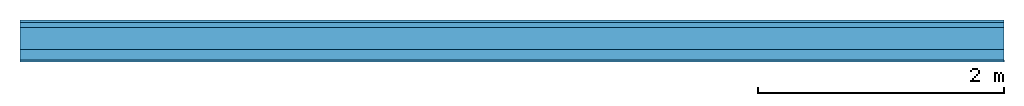
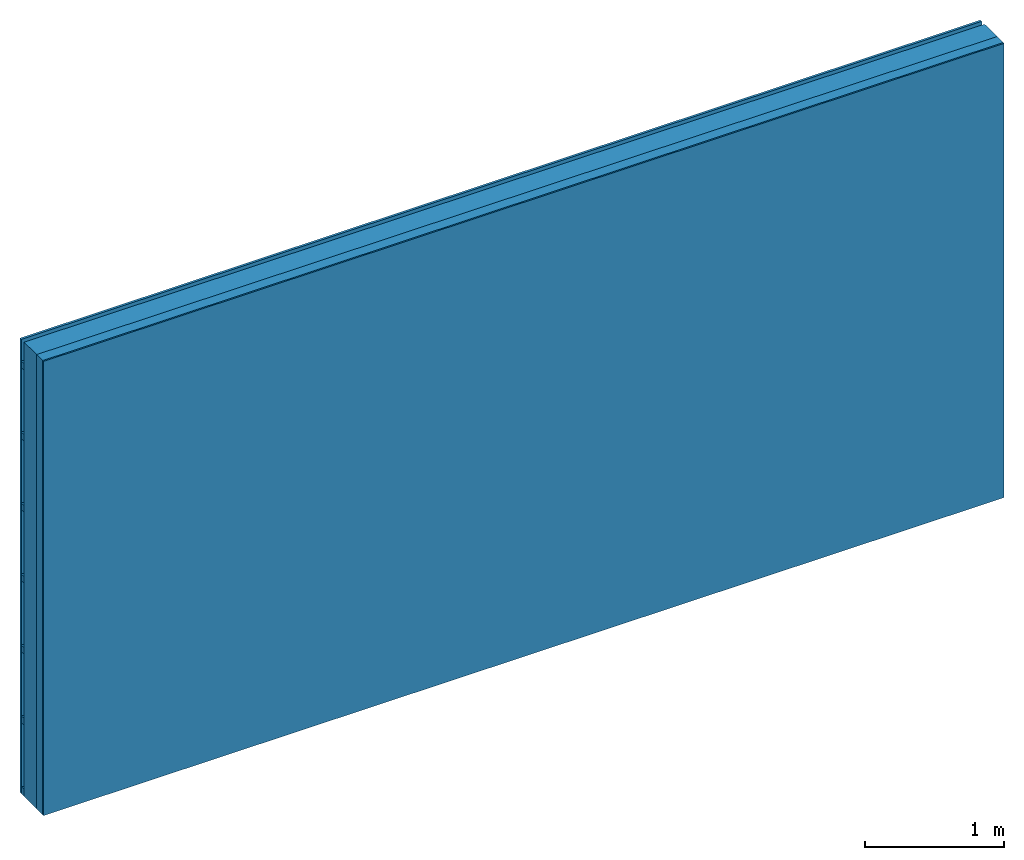
# One storey: 3 plates, 2 members, 1 element without a shape of its own.
"""IFC4 building model written with IfcOpenShell, lengths in metres."""

from ifc_helpers import new_model, si_unit, derived_unit, direction, frame, frame_2d, origin, origin_with_axes, place, context, project, spatial, rectangle, extrude, material, layer, layer_set, type_object, element, aggregate, save


model = new_model("IFC4")

# Units and contexts
plan_context = context("Plan", 3, precision=1e-05, world=origin(), true_north=direction((0.0, 1.0)))
model_context = context("Model", 3, precision=1e-05, world=origin(), true_north=direction((0.0, 1.0)))
ifc_project = project(units=[si_unit("LENGTHUNIT", "METRE"), derived_unit("SOUNDPRESSUREUNIT", [(si_unit("PRESSUREUNIT", "PASCAL", prefix="MICRO"), 0)]), si_unit("ENERGYUNIT", "JOULE", prefix="MEGA"), si_unit("MASSUNIT", "GRAM", prefix="KILO"), derived_unit("THERMALTRANSMITTANCEUNIT", [(si_unit("POWERUNIT", "WATT"), 1), (si_unit("AREAUNIT", "SQUARE_METRE"), -1), (si_unit("THERMODYNAMICTEMPERATUREUNIT", "KELVIN"), -1)]), derived_unit("AREADENSITYUNIT", [(si_unit("MASSUNIT", "GRAM", prefix="KILO"), 1), (si_unit("AREAUNIT", "SQUARE_METRE"), -1)]), derived_unit("USERDEFINED", [(si_unit("ENERGYUNIT", "JOULE", prefix="MEGA"), 1), (si_unit("AREAUNIT", "SQUARE_METRE"), -1)])], contexts=[plan_context, model_context])

# Site, building, storey
site = spatial("IfcSite", under=ifc_project)
building_placement = place(None, origin())
building = spatial("IfcBuilding", under=site, at=building_placement)
storey_placement = place(building_placement, origin())
storey = spatial("IfcBuildingStorey", under=building, at=storey_placement)

# Wall, members, plates
ifc_material_1 = material(Name="Wood cladding horizontal, closed")
ifc_layer_1 = layer(ifc_material_1, 0.02, Name="Cover 1st layer")
ifc_layer_2 = layer(None, 0.04, Name="Battens / profiles (ventilation)")
ifc_material_2 = material(Category="10.009")
ifc_layer_3 = layer(ifc_material_2, 0.18, Name="outside 1st layer")
ifc_material_3 = material(Name="of the art")
ifc_layer_4 = layer(ifc_material_3, 0.0, Name="Bond")
ifc_layer_5 = layer(None, 0.087, Name="Support")
ifc_layer_6 = layer(ifc_material_3, 0.0, Name="Bond")
ifc_material_4 = material(Name="Plasterboard type A", Category="03.008")
ifc_layer_7 = layer(ifc_material_4, 0.0125, Name="1st layer")
ifc_material_5 = material(Name="joints", Category="04.017")
ifc_layer_8 = layer(ifc_material_5, 0.0, Name="Surface")
ifc_layer_set = layer_set([ifc_layer_1, ifc_layer_2, ifc_layer_3, ifc_layer_4, ifc_layer_5, ifc_layer_6, ifc_layer_7, ifc_layer_8])
wall_type = type_object("IfcWallType", Name="D1010", PredefinedType="NOTDEFINED", material=ifc_layer_set)
wall_placement = place(None, frame((0.0, 0.0, 0.0), z_axis=(0.0, -1.0, 0.0), x_axis=(1.0, 0.0, 0.0)))
wall = element("IfcWall", 1, at=wall_placement, inside=storey, type_object=wall_type, material=ifc_layer_set, Name="Wall #1")
ifc_material_6 = material()
member_1_placement = place(wall_placement, origin())
member_1 = element("IfcMember", 2, at=member_1_placement, material=ifc_material_6, Name="Battens / profiles (ventilation)", context=plan_context, shape_type="SweptSolid", body=[
    extrude(rectangle(XDim=0.06, YDim=0.04, at=frame_2d((0.03, 0.02), x_axis=(1.0, 0.0))), frame((0.0, 0.0, 0.02), z_axis=(1.0, 0.0, 0.0), x_axis=(0.0, 1.0, 0.0)), (0.0, 0.0, 1.0), 8.0),
    extrude(rectangle(XDim=0.06, YDim=0.04, at=frame_2d((0.03, 0.02), x_axis=(1.0, 0.0))), frame((0.0, 0.625, 0.02), z_axis=(1.0, 0.0, 0.0), x_axis=(0.0, 1.0, 0.0)), (0.0, 0.0, 1.0), 8.0),
    extrude(rectangle(XDim=0.06, YDim=0.04, at=frame_2d((0.03, 0.02), x_axis=(1.0, 0.0))), frame((0.0, 1.25, 0.02), z_axis=(1.0, 0.0, 0.0), x_axis=(0.0, 1.0, 0.0)), (0.0, 0.0, 1.0), 8.0),
    extrude(rectangle(XDim=0.06, YDim=0.04, at=frame_2d((0.03, 0.02), x_axis=(1.0, 0.0))), frame((0.0, 1.875, 0.02), z_axis=(1.0, 0.0, 0.0), x_axis=(0.0, 1.0, 0.0)), (0.0, 0.0, 1.0), 8.0),
    extrude(rectangle(XDim=0.06, YDim=0.04, at=frame_2d((0.03, 0.02), x_axis=(1.0, 0.0))), frame((0.0, 2.5, 0.02), z_axis=(1.0, 0.0, 0.0), x_axis=(0.0, 1.0, 0.0)), (0.0, 0.0, 1.0), 8.0),
    extrude(rectangle(XDim=0.06, YDim=0.04, at=frame_2d((0.03, 0.02), x_axis=(1.0, 0.0))), frame((0.0, 3.125, 0.02), z_axis=(1.0, 0.0, 0.0), x_axis=(0.0, 1.0, 0.0)), (0.0, 0.0, 1.0), 8.0),
    extrude(rectangle(XDim=0.06, YDim=0.04, at=frame_2d((0.03, 0.02), x_axis=(1.0, 0.0))), frame((0.0, 3.75, 0.02), z_axis=(1.0, 0.0, 0.0), x_axis=(0.0, 1.0, 0.0)), (0.0, 0.0, 1.0), 8.0),
])
ifc_material_7 = material(Name="Solid timber panel")
member_2_placement = place(wall_placement, origin())
member_2 = element("IfcMember", 3, at=member_2_placement, material=ifc_material_7, Name="Support", context=plan_context, shape_type="SweptSolid", body=[
    extrude(rectangle(XDim=1.0, YDim=0.087, at=frame_2d((0.5, 0.0435), x_axis=(1.0, 0.0))), frame((0.0, 4.0, 0.24), z_axis=(0.0, -1.0, 0.0), x_axis=(1.0, 0.0, 0.0)), (0.0, 0.0, 1.0), 4.0),
    extrude(rectangle(XDim=1.0, YDim=0.087, at=frame_2d((0.5, 0.0435), x_axis=(1.0, 0.0))), frame((1.0, 4.0, 0.24), z_axis=(0.0, -1.0, 0.0), x_axis=(1.0, 0.0, 0.0)), (0.0, 0.0, 1.0), 4.0),
    extrude(rectangle(XDim=1.0, YDim=0.087, at=frame_2d((0.5, 0.0435), x_axis=(1.0, 0.0))), frame((2.0, 4.0, 0.24), z_axis=(0.0, -1.0, 0.0), x_axis=(1.0, 0.0, 0.0)), (0.0, 0.0, 1.0), 4.0),
    extrude(rectangle(XDim=1.0, YDim=0.087, at=frame_2d((0.5, 0.0435), x_axis=(1.0, 0.0))), frame((3.0, 4.0, 0.24), z_axis=(0.0, -1.0, 0.0), x_axis=(1.0, 0.0, 0.0)), (0.0, 0.0, 1.0), 4.0),
    extrude(rectangle(XDim=1.0, YDim=0.087, at=frame_2d((0.5, 0.0435), x_axis=(1.0, 0.0))), frame((4.0, 4.0, 0.24), z_axis=(0.0, -1.0, 0.0), x_axis=(1.0, 0.0, 0.0)), (0.0, 0.0, 1.0), 4.0),
    extrude(rectangle(XDim=1.0, YDim=0.087, at=frame_2d((0.5, 0.0435), x_axis=(1.0, 0.0))), frame((5.0, 4.0, 0.24), z_axis=(0.0, -1.0, 0.0), x_axis=(1.0, 0.0, 0.0)), (0.0, 0.0, 1.0), 4.0),
    extrude(rectangle(XDim=1.0, YDim=0.087, at=frame_2d((0.5, 0.0435), x_axis=(1.0, 0.0))), frame((6.0, 4.0, 0.24), z_axis=(0.0, -1.0, 0.0), x_axis=(1.0, 0.0, 0.0)), (0.0, 0.0, 1.0), 4.0),
    extrude(rectangle(XDim=1.0, YDim=0.087, at=frame_2d((0.5, 0.0435), x_axis=(1.0, 0.0))), frame((7.0, 4.0, 0.24), z_axis=(0.0, -1.0, 0.0), x_axis=(1.0, 0.0, 0.0)), (0.0, 0.0, 1.0), 4.0),
])
plate_1_placement = place(wall_placement, origin())
plate_1 = element("IfcPlate", 4, at=plate_1_placement, material=ifc_material_1, Name="Cover 1st layer", context=plan_context, shape_type="SweptSolid", body=[
    extrude(rectangle(XDim=8.0, YDim=4.0, at=frame_2d((4.0, 2.0), x_axis=(1.0, 0.0))), origin_with_axes(), (0.0, 0.0, 1.0), 0.02),
])
plate_2_placement = place(wall_placement, origin())
plate_2 = element("IfcPlate", 5, at=plate_2_placement, material=ifc_material_2, Name="outside 1st layer", context=plan_context, shape_type="SweptSolid", body=[
    extrude(rectangle(XDim=8.0, YDim=4.0, at=frame_2d((4.0, 2.0), x_axis=(1.0, 0.0))), frame((0.0, 0.0, 0.06), z_axis=(0.0, 0.0, 1.0), x_axis=(1.0, 0.0, 0.0)), (0.0, 0.0, 1.0), 0.18),
])
plate_3_placement = place(wall_placement, origin())
plate_3 = element("IfcPlate", 6, at=plate_3_placement, material=ifc_material_4, Name="1st layer", context=plan_context, shape_type="SweptSolid", body=[
    extrude(rectangle(XDim=8.0, YDim=4.0, at=frame_2d((4.0, 2.0), x_axis=(1.0, 0.0))), frame((0.0, 0.0, 0.327), z_axis=(0.0, 0.0, 1.0), x_axis=(1.0, 0.0, 0.0)), (0.0, 0.0, 1.0), 0.0125),
])
aggregate(wall, [plate_1, member_1, plate_2, member_2, plate_3])

save(model, "model.ifc")
